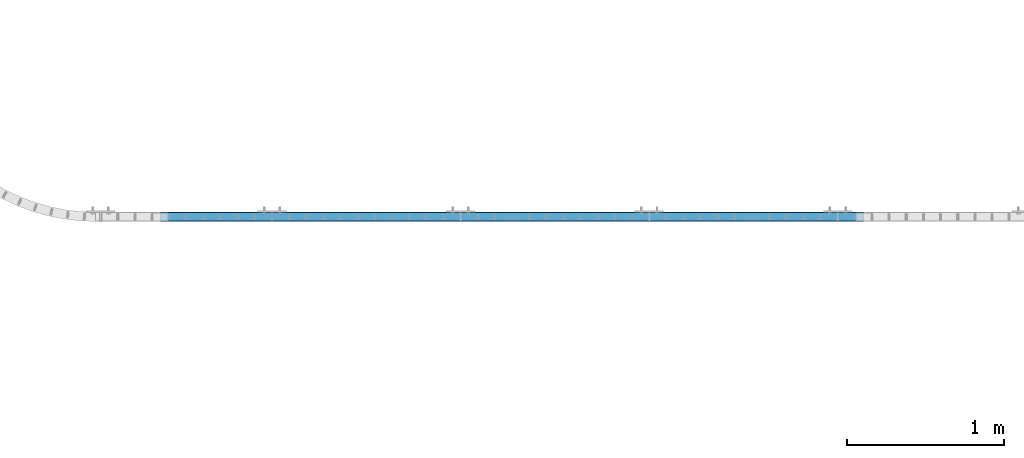
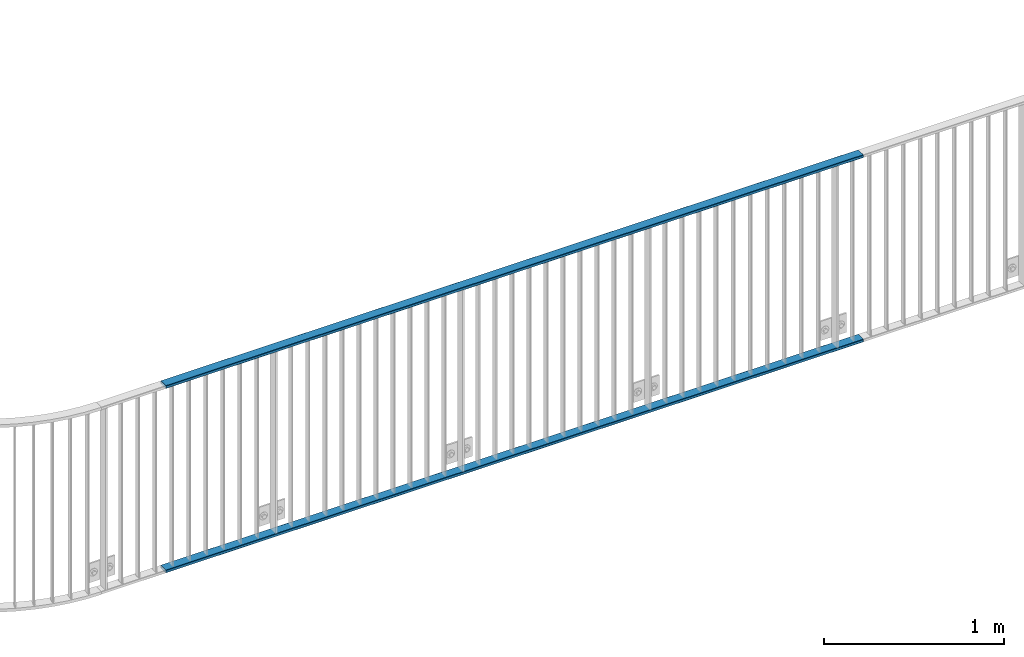
# One storey, part 2 of 156: 2 beams, 1 element without a shape of its own.
"""IFC2X3 building model written with IfcOpenShell, lengths in millimetres."""

from ifc_helpers import new_model, si_unit, frame, origin_with_axes, origin_2d_with_axis, place, context, subcontext, project, spatial, hollow_rectangle, extrude, material, type_object, element, aggregate, save


model = new_model("IFC2X3")

# Units and contexts
model_context = context("Model", 3, precision=1e-05, world=origin_with_axes())
body_context = subcontext(model_context, "Body", "Model", "MODEL_VIEW")
ifc_project = project(units=[si_unit("LENGTHUNIT", "METRE", prefix="MILLI"), si_unit("AREAUNIT", "SQUARE_METRE"), si_unit("VOLUMEUNIT", "CUBIC_METRE"), si_unit("MASSUNIT", "GRAM", prefix="KILO"), si_unit("TIMEUNIT", "SECOND"), si_unit("PLANEANGLEUNIT", "RADIAN"), si_unit("SOLIDANGLEUNIT", "STERADIAN"), si_unit("THERMODYNAMICTEMPERATUREUNIT", "DEGREE_CELSIUS"), si_unit("LUMINOUSINTENSITYUNIT", "LUMEN")], contexts=[model_context])

# Site, building, storey
site_placement = place(None, origin_with_axes())
site = spatial("IfcSite", under=ifc_project, at=site_placement, CompositionType="ELEMENT")
building_placement = place(site_placement, origin_with_axes())
building = spatial("IfcBuilding", under=site, at=building_placement, Name="Undefined", CompositionType="ELEMENT")
storey_placement = place(building_placement, origin_with_axes())
storey = spatial("IfcBuildingStorey", under=building, at=storey_placement, Name="Undefined", CompositionType="ELEMENT", Elevation=0.0)

# Assembly, beams
assembly_placement = place(storey_placement, origin_with_axes())
assembly = element("IfcElementAssembly", 1, at=assembly_placement, inside=storey, AssemblyPlace="NOTDEFINED", PredefinedType="RIGID_FRAME")
ifc_material = material(Name="STEEL/S235JR")
beam_type = type_object("IfcBeamType", Name="K60/20/2", PredefinedType="NOTDEFINED")
beam_1_placement = place(assembly_placement, frame((9890.91499998614, 10879.9998016357, 3990.0), z_axis=(0.0, 1.0, 0.0), x_axis=(1.0, 0.0, 0.0)))
beam_1 = element("IfcBeam", 2, at=beam_1_placement, type_object=beam_type, material=ifc_material, ObjectType="K60/20/2", context=body_context, shape_type="SweptSolid", body=[
    extrude(hollow_rectangle(XDim=20.0, YDim=60.0, WallThickness=2.0, InnerFilletRadius=2.0, OuterFilletRadius=4.0, at=origin_2d_with_axis()), frame((4472.73074235093, 0.0, 0.0), z_axis=(-1.0, 0.0, 0.0), x_axis=(0.0, -1.0, 0.0)), (0.0, 0.0, 1.0), 4472.73),
])
beam_2_placement = place(assembly_placement, frame((9890.91499999898, 10879.9998016357, 2740.0), z_axis=(0.0, 1.0, 0.0), x_axis=(1.0, 0.0, 0.0)))
beam_2 = element("IfcBeam", 3, at=beam_2_placement, type_object=beam_type, material=ifc_material, ObjectType="K60/20/2", context=body_context, shape_type="SweptSolid", body=[
    extrude(hollow_rectangle(XDim=20.0, YDim=60.0, WallThickness=2.0, InnerFilletRadius=2.0, OuterFilletRadius=4.0, at=origin_2d_with_axis()), frame((4472.735, 0.0, 0.0), z_axis=(-1.0, 0.0, 0.0), x_axis=(0.0, -1.0, 0.0)), (0.0, 0.0, 1.0), 4472.73),
])
aggregate(assembly, [beam_1, beam_2])

save(model, "model.ifc")
